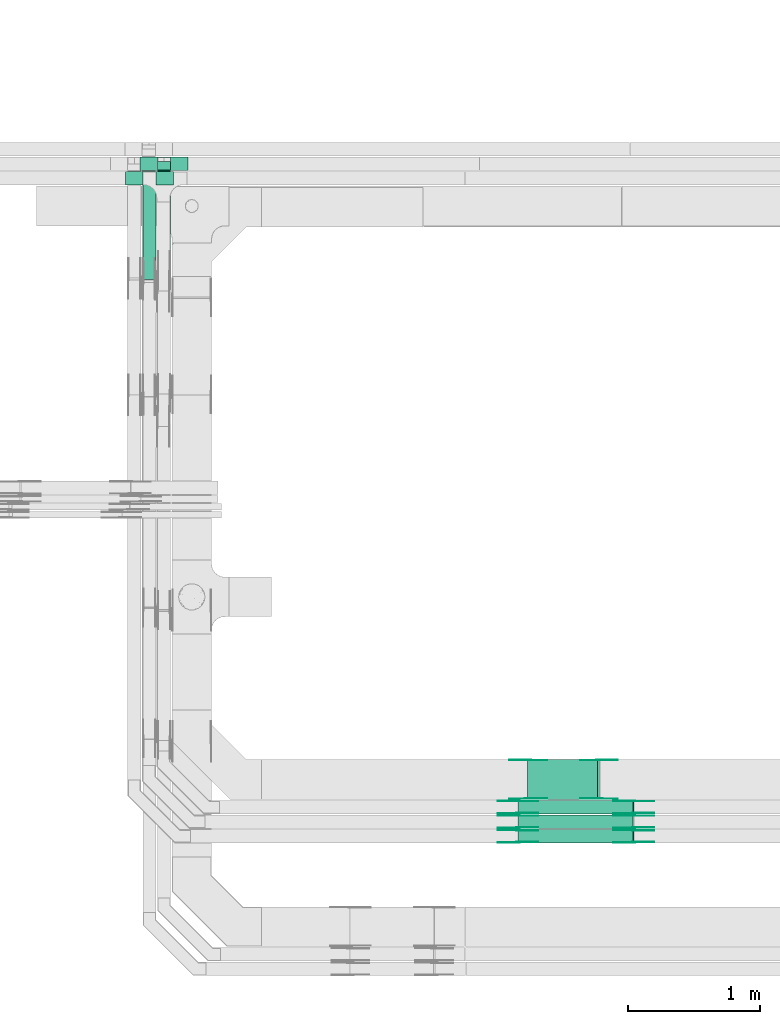
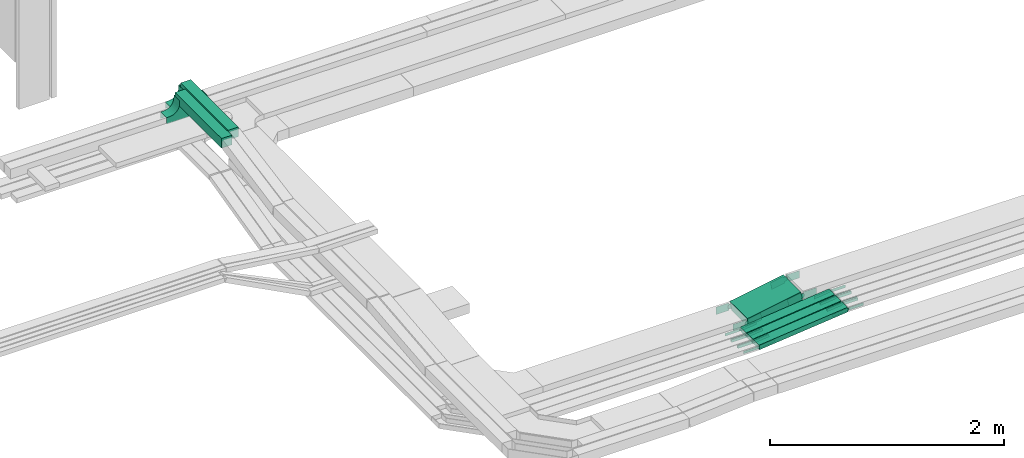
# One storey, part 10 of 33: 34 flow fittings, 6 flow segments.
"""IFC2X3 building model written with IfcOpenShell, lengths in millimetres."""

from ifc_helpers import new_model, entity, si_unit, converted_unit, derived_unit, direction, frame, frame_2d, origin, origin_2d_with_axis, place, context, subcontext, project, spatial, polyline, circle_curve, parameter, trimmed, segment, composite_curve, rectangle, outline, extrude, source, transform, mapped, material, material_list, type_object, type_shapes, element, save


model = new_model("IFC2X3")

# Units and contexts
model_context = context("Model", 3, precision=0.01, world=origin(), true_north=direction((6.12303176911189e-17, 1.0)))
body_context = subcontext(model_context, "Body", "Model", "MODEL_VIEW")
ifc_project = project(units=[si_unit("LENGTHUNIT", "METRE", prefix="MILLI"), si_unit("AREAUNIT", "SQUARE_METRE"), si_unit("VOLUMEUNIT", "CUBIC_METRE"), converted_unit("PLANEANGLEUNIT", "DEGREE", entity("IfcRatioMeasure", 0.0174532925199433), si_unit("PLANEANGLEUNIT", "RADIAN"), dimensions=[0, 0, 0, 0, 0, 0, 0]), si_unit("MASSUNIT", "GRAM", prefix="KILO"), derived_unit("MASSDENSITYUNIT", [(si_unit("MASSUNIT", "GRAM", prefix="KILO"), 1), (si_unit("LENGTHUNIT", "METRE"), -3)]), derived_unit("MOMENTOFINERTIAUNIT", [(si_unit("LENGTHUNIT", "METRE"), 4)]), si_unit("TIMEUNIT", "SECOND"), si_unit("FREQUENCYUNIT", "HERTZ"), si_unit("THERMODYNAMICTEMPERATUREUNIT", "DEGREE_CELSIUS"), derived_unit("THERMALTRANSMITTANCEUNIT", [(si_unit("MASSUNIT", "GRAM", prefix="KILO"), 1), (si_unit("THERMODYNAMICTEMPERATUREUNIT", "KELVIN"), -1), (si_unit("TIMEUNIT", "SECOND"), -3)]), derived_unit("VOLUMETRICFLOWRATEUNIT", [(si_unit("LENGTHUNIT", "METRE"), 3), (si_unit("TIMEUNIT", "SECOND"), -1)]), derived_unit("MASSFLOWRATEUNIT", [(si_unit("MASSUNIT", "GRAM", prefix="KILO"), 1), (si_unit("TIMEUNIT", "SECOND"), -1)]), derived_unit("ROTATIONALFREQUENCYUNIT", [(si_unit("TIMEUNIT", "SECOND"), -1)]), si_unit("ELECTRICCURRENTUNIT", "AMPERE"), si_unit("ELECTRICVOLTAGEUNIT", "VOLT"), si_unit("POWERUNIT", "WATT"), si_unit("FORCEUNIT", "NEWTON", prefix="KILO"), si_unit("ILLUMINANCEUNIT", "LUX"), si_unit("LUMINOUSFLUXUNIT", "LUMEN"), si_unit("LUMINOUSINTENSITYUNIT", "CANDELA"), derived_unit("USERDEFINED", [(si_unit("MASSUNIT", "GRAM", prefix="KILO"), -1), (si_unit("LENGTHUNIT", "METRE"), -2), (si_unit("TIMEUNIT", "SECOND"), 3), (si_unit("LUMINOUSFLUXUNIT", "LUMEN"), 1)]), derived_unit("LINEARVELOCITYUNIT", [(si_unit("LENGTHUNIT", "METRE"), 1), (si_unit("TIMEUNIT", "SECOND"), -1)]), si_unit("PRESSUREUNIT", "PASCAL"), derived_unit("USERDEFINED", [(si_unit("LENGTHUNIT", "METRE"), -2), (si_unit("MASSUNIT", "GRAM", prefix="KILO"), 1), (si_unit("TIMEUNIT", "SECOND"), -2)]), derived_unit("LINEARFORCEUNIT", [(si_unit("MASSUNIT", "GRAM", prefix="KILO"), 1), (si_unit("LENGTHUNIT", "METRE"), 1), (si_unit("TIMEUNIT", "SECOND"), -2), (si_unit("LENGTHUNIT", "METRE"), -1)]), derived_unit("PLANARFORCEUNIT", [(si_unit("MASSUNIT", "GRAM", prefix="KILO"), 1), (si_unit("LENGTHUNIT", "METRE"), 1), (si_unit("TIMEUNIT", "SECOND"), -2), (si_unit("LENGTHUNIT", "METRE"), -2)])], contexts=[model_context])

# Site, building, storey
site_placement = place(None, frame((0.0, -0.00077364408347762, 0.0)))
site = spatial("IfcSite", under=ifc_project, at=site_placement, CompositionType="ELEMENT")
building_placement = place(site_placement, origin())
building = spatial("IfcBuilding", under=site, at=building_placement, CompositionType="ELEMENT")
storey_placement = place(building_placement, frame((0.0, 0.0, 8100.0)))
storey = spatial("IfcBuildingStorey", under=building, at=storey_placement, CompositionType="ELEMENT", Elevation=8100.0)

# Flow segments
cable_carrier_segment_type = type_object("IfcCableCarrierSegmentType", PredefinedType="CABLETRAYSEGMENT")
flow_segment_1_placement = place(storey_placement, frame((20936.6119881971, 9844.99855346682, 2501.75364186438)))
element("IfcFlowSegment", 1, at=flow_segment_1_placement, inside=storey, type_object=cable_carrier_segment_type, context=body_context, shape_type="SweptSolid", body=[
    extrude(rectangle(XDim=99.9999999999988, YDim=300.000000000001, at=origin_2d_with_axis()), frame((8.68240888335646, 150.0, 49.2403876506095), z_axis=(0.98480775301218, 0.0, 0.173648177667088), x_axis=(-0.173648177667088, 0.0, 0.98480775301218)), (0.0, 0.0, 1.0), 535.73303583543),
])
flow_segment_2_placement = place(storey_placement, frame((20862.9583340614, 9515.4751966114, 2500.38811547991)))
element("IfcFlowSegment", 2, at=flow_segment_2_placement, inside=storey, type_object=cable_carrier_segment_type, context=body_context, shape_type="SweptSolid", body=[
    extrude(rectangle(XDim=49.9999999999994, YDim=100.000000000001, at=origin_2d_with_axis()), frame((2.56705800013261, 50.0, 24.8678550185564), z_axis=(0.994714200742268, 0.0, 0.102682320005306), x_axis=(-0.102682320005306, 0.0, 0.994714200742268)), (0.0, 0.0, 1.0), 876.300550533938),
])
flow_segment_3_placement = place(storey_placement, frame((20863.3945823031, 9625.47519661138, 2495.89018816181)))
element("IfcFlowSegment", 3, at=flow_segment_3_placement, inside=storey, type_object=cable_carrier_segment_type, context=body_context, shape_type="SweptSolid", body=[
    extrude(rectangle(XDim=50.0000000000006, YDim=100.000000000001, at=origin_2d_with_axis()), frame((2.69638057909248, 50.0, 24.854165280146), z_axis=(0.994166611205742, 0.0, 0.107855223163698), x_axis=(-0.107855223163698, 0.0, 0.994166611205742)), (0.0, 0.0, 1.0), 875.337574347223),
])
flow_segment_4_placement = place(storey_placement, frame((20863.4181872232, 9734.99855346672, 2495.73503380325)))
element("IfcFlowSegment", 4, at=flow_segment_4_placement, inside=storey, type_object=cable_carrier_segment_type, context=body_context, shape_type="SweptSolid", body=[
    extrude(rectangle(XDim=50.0000000000009, YDim=99.9999999999989, at=origin_2d_with_axis()), frame((2.66402572466178, 50.0, 24.8576540916146), z_axis=(0.994306163664565, 0.0, 0.106561028986469), x_axis=(-0.106561028986469, 0.0, 0.994306163664565)), (0.0, 0.0, 1.0), 875.4694098787),
])
flow_segment_5_placement = place(storey_placement, frame((18026.0523642072, 13775.3539584061, 3012.11789102291)))
element("IfcFlowSegment", 5, at=flow_segment_5_placement, inside=storey, type_object=cable_carrier_segment_type, context=body_context, shape_type="SweptSolid", body=[
    extrude(rectangle(XDim=793.729321151489, YDim=99.9999999999989, at=frame_2d((-1.08002495835535e-12, 0.0), x_axis=(1.0, 0.0))), frame((50.0, 396.864660575752, 0.0), z_axis=(0.0, 0.0, 1.0), x_axis=(0.0, -1.0, 0.0)), (0.0, 0.0, 1.0), 99.9999999999989),
])
flow_segment_6_placement = place(storey_placement, frame((18136.0523642072, 13853.7575403383, 3012.11789102291)))
element("IfcFlowSegment", 6, at=flow_segment_6_placement, inside=storey, type_object=cable_carrier_segment_type, context=body_context, shape_type="SweptSolid", body=[
    extrude(rectangle(XDim=814.055739224407, YDim=99.9999999999989, at=frame_2d((1.08002495835535e-12, 0.0), x_axis=(1.0, 0.0))), frame((50.0, 407.027869612207, 0.0), z_axis=(0.0, 0.0, 1.0), x_axis=(0.0, -1.0, 0.0)), (0.0, 0.0, 1.0), 99.9999999999989),
])

# Flow fittings
ifc_material_1 = material(Name="G")
cable_carrier_fitting_type_1 = type_object("IfcCableCarrierFittingType", PredefinedType="NOTDEFINED", material=ifc_material_1)
shared_shape_1 = source(origin(), body_context, "Body", "SweptSolid", [
    extrude(outline(composite_curve([segment(trimmed(circle_curve(frame_2d((-44.5901162790698, 0.0), x_axis=(1.0, 0.0)), 12.5), [parameter(90.0000000000007)], [parameter(270.0)], True, "PARAMETER"), True, "CONTINUOUS"), segment(polyline([(-44.5901162790697, -12.5), (-33.0901162790698, -12.5)]), True, "CONTINUOUS"), segment(polyline([(-33.0901162790698, -12.5), (-31.2296511627907, -14.5)]), True, "CONTINUOUS"), segment(polyline([(-31.2296511627907, -14.5), (108.90988372093, -14.5)]), True, "CONTINUOUS"), segment(polyline([(108.90988372093, -14.5), (108.90988372093, 14.5)]), True, "CONTINUOUS"), segment(polyline([(108.90988372093, 14.5), (-31.2296511627907, 14.5)]), True, "CONTINUOUS"), segment(polyline([(-31.2296511627907, 14.5), (-33.0901162790698, 12.5)]), True, "CONTINUOUS"), segment(polyline([(-33.0901162790698, 12.5), (-44.5901162790699, 12.5)]), True, "CONTINUOUS")], self_intersect=False)), frame((44.5901162790698, 0.0, 0.0), z_axis=(0.0, 0.0, -1.0), x_axis=(1.0, 0.0, 0.0)), (0.0, 0.0, -1.0), 2.0),
])
type_shapes(cable_carrier_fitting_type_1, [shared_shape_1])
for number, where, z_axis, x_axis in (
    (7, (21739.6736562129, 9520.01519660124, 2615.49251454772), (0.0, -1.0, 0.0), (-0.994714200742261, 0.0, -0.102682320005368)),
    (8, (21738.8758454154, 9630.01519660122, 2615.43110636497), (0.0, -1.0, 0.0), (-0.99416661120574, 0.0, -0.107855223163717)),
    (9, (21739.1018729423, 9739.53855345656, 2614.15529134039), (0.0, -1.0, 0.0), (-0.994306163664572, 0.0, -0.106561028986405)),
    (10, (20863.5374702987, 9720.93519662154, 2520.46732994372), (0.0, 1.0, 0.0), (-1.0, 0.0, 0.0)),
    (11, (20863.5471832954, 9830.45855347687, 2520.32100561212), (0.0, 1.0, 0.0), (-1.0, 0.0, 0.0)),
    (12, (20863.0457296445, 9610.93519662156, 2525.0), (0.0, 1.0, 0.0), (-1.0, 0.0, 0.0)),
):
    element("IfcFlowFitting", number, at=place(storey_placement, frame(where, z_axis=z_axis, x_axis=x_axis)), inside=storey, type_object=cable_carrier_fitting_type_1, material=ifc_material_1, context=body_context, shape_type="MappedRepresentation", body=[
        mapped(shared_shape_1, transform((0.0, 0.0, 0.0), scale=1.0)),
    ])
cable_carrier_fitting_type_2 = type_object("IfcCableCarrierFittingType", PredefinedType="NOTDEFINED", material=ifc_material_1)
shared_shape_2 = source(origin(), body_context, "Body", "SweptSolid", [
    extrude(outline(composite_curve([segment(trimmed(circle_curve(frame_2d((-44.5901162790697, 0.0), x_axis=(1.0, 0.0)), 12.5), [parameter(90.0000000000007)], [parameter(270.0)], True, "PARAMETER"), True, "CONTINUOUS"), segment(polyline([(-44.5901162790697, -12.5), (-33.0901162790697, -12.5)]), True, "CONTINUOUS"), segment(polyline([(-33.0901162790697, -12.5), (-31.2296511627907, -14.5)]), True, "CONTINUOUS"), segment(polyline([(-31.2296511627907, -14.5), (108.90988372093, -14.5)]), True, "CONTINUOUS"), segment(polyline([(108.90988372093, -14.5), (108.90988372093, 14.5)]), True, "CONTINUOUS"), segment(polyline([(108.90988372093, 14.5), (-31.2296511627907, 14.5)]), True, "CONTINUOUS"), segment(polyline([(-31.2296511627907, 14.5), (-33.0901162790698, 12.5)]), True, "CONTINUOUS"), segment(polyline([(-33.0901162790698, 12.5), (-44.5901162790699, 12.5)]), True, "CONTINUOUS")], self_intersect=False)), frame((44.5901162790697, 0.0, 0.0)), (0.0, 0.0, 1.0), 2.0),
])
type_shapes(cable_carrier_fitting_type_2, [shared_shape_2])
for number, where, z_axis, x_axis in (
    (13, (21739.6736562129, 9610.93519662156, 2615.49251454772), (0.0, 1.0, 0.0), (-0.994714200742261, 0.0, -0.102682320005368)),
    (14, (21738.8758454154, 9720.93519662154, 2615.43110636498), (0.0, 1.0, 0.0), (-0.99416661120574, 0.0, -0.107855223163717)),
    (15, (21739.1018729423, 9830.45855347688, 2614.15529134039), (0.0, 1.0, 0.0), (-0.994306163664572, 0.0, -0.106561028986405)),
    (16, (20863.5374702987, 9630.01519660122, 2520.46732994372), (0.0, -1.0, 0.0), (-1.0, 0.0, 0.0)),
    (17, (20863.5471832954, 9739.53855345656, 2520.32100561212), (0.0, -1.0, 0.0), (-1.0, 0.0, 0.0)),
    (18, (20863.0457296445, 9520.01519660125, 2525.0), (0.0, -1.0, 0.0), (-1.0, 0.0, 0.0)),
):
    element("IfcFlowFitting", number, at=place(storey_placement, frame(where, z_axis=z_axis, x_axis=x_axis)), inside=storey, type_object=cable_carrier_fitting_type_2, material=ifc_material_1, context=body_context, shape_type="MappedRepresentation", body=[
        mapped(shared_shape_2, transform((0.0, 0.0, 0.0), scale=1.0)),
    ])
cable_carrier_fitting_type_3 = type_object("IfcCableCarrierFittingType", PredefinedType="NOTDEFINED", material=ifc_material_1)
shared_shape_3 = source(origin(), body_context, "Body", "SweptSolid", [
    extrude(outline(composite_curve([segment(trimmed(circle_curve(frame_2d((-44.5901162790698, 0.0), x_axis=(1.0, 0.0)), 12.5), [parameter(90.0000000000007)], [parameter(270.0)], True, "PARAMETER"), True, "CONTINUOUS"), segment(polyline([(-44.5901162790697, -12.5), (-33.0901162790698, -12.5)]), True, "CONTINUOUS"), segment(polyline([(-33.0901162790698, -12.5), (-31.2296511627907, -14.5)]), True, "CONTINUOUS"), segment(polyline([(-31.2296511627907, -14.5), (108.90988372093, -14.5)]), True, "CONTINUOUS"), segment(polyline([(108.90988372093, -14.5), (108.90988372093, 14.5)]), True, "CONTINUOUS"), segment(polyline([(108.90988372093, 14.5), (-31.2296511627907, 14.5)]), True, "CONTINUOUS"), segment(polyline([(-31.2296511627907, 14.5), (-33.0901162790698, 12.5)]), True, "CONTINUOUS"), segment(polyline([(-33.0901162790698, 12.5), (-44.5901162790699, 12.5)]), True, "CONTINUOUS")], self_intersect=False)), frame((44.5901162790698, 0.0, 0.0), z_axis=(0.0, 0.0, -1.0), x_axis=(1.0, 0.0, 0.0)), (0.0, 0.0, -1.0), 2.0),
])
type_shapes(cable_carrier_fitting_type_3, [shared_shape_3])
for number, where, z_axis, x_axis in (
    (19, (21739.6736562129, 9608.93519662156, 2615.49251454772), (0.0, 1.0, 0.0), (1.0, 0.0, 0.0)),
    (20, (21738.8758454154, 9718.93519662154, 2615.43110636497), (0.0, 1.0, 0.0), (1.0, 0.0, 0.0)),
    (21, (21739.1018729423, 9828.45855347688, 2614.15529134039), (0.0, 1.0, 0.0), (1.0, 0.0, 0.0)),
    (22, (20863.5374702987, 9632.01519660122, 2520.46732994373), (0.0, -1.0, 0.0), (0.994166611205741, 0.0, 0.107855223163708)),
    (23, (20863.5471832954, 9741.53855345656, 2520.32100561212), (0.0, -1.0, 0.0), (0.994306163664573, 0.0, 0.106561028986395)),
    (24, (20863.0457296444, 9522.01519660125, 2525.0), (0.0, -1.0, 0.0), (0.994714200742268, 0.0, 0.102682320005305)),
):
    element("IfcFlowFitting", number, at=place(storey_placement, frame(where, z_axis=z_axis, x_axis=x_axis)), inside=storey, type_object=cable_carrier_fitting_type_3, material=ifc_material_1, context=body_context, shape_type="MappedRepresentation", body=[
        mapped(shared_shape_3, transform((0.0, 0.0, 0.0), scale=1.0)),
    ])
cable_carrier_fitting_type_4 = type_object("IfcCableCarrierFittingType", PredefinedType="NOTDEFINED", material=ifc_material_1)
shared_shape_4 = source(origin(), body_context, "Body", "SweptSolid", [
    extrude(outline(composite_curve([segment(trimmed(circle_curve(frame_2d((-44.5901162790697, 0.0), x_axis=(1.0, 0.0)), 12.5), [parameter(90.0000000000007)], [parameter(270.0)], True, "PARAMETER"), True, "CONTINUOUS"), segment(polyline([(-44.5901162790697, -12.5), (-33.0901162790697, -12.5)]), True, "CONTINUOUS"), segment(polyline([(-33.0901162790697, -12.5), (-31.2296511627907, -14.5)]), True, "CONTINUOUS"), segment(polyline([(-31.2296511627907, -14.5), (108.90988372093, -14.5)]), True, "CONTINUOUS"), segment(polyline([(108.90988372093, -14.5), (108.90988372093, 14.5)]), True, "CONTINUOUS"), segment(polyline([(108.90988372093, 14.5), (-31.2296511627907, 14.5)]), True, "CONTINUOUS"), segment(polyline([(-31.2296511627907, 14.5), (-33.0901162790698, 12.5)]), True, "CONTINUOUS"), segment(polyline([(-33.0901162790698, 12.5), (-44.5901162790699, 12.5)]), True, "CONTINUOUS")], self_intersect=False)), frame((44.5901162790697, 0.0, 0.0)), (0.0, 0.0, 1.0), 2.0),
])
type_shapes(cable_carrier_fitting_type_4, [shared_shape_4])
for number, where, z_axis, x_axis in (
    (25, (21739.6736562129, 9522.01519660124, 2615.49251454771), (0.0, -1.0, 0.0), (1.0, 0.0, 0.0)),
    (26, (21738.8758454154, 9632.01519660122, 2615.43110636497), (0.0, -1.0, 0.0), (1.0, 0.0, 0.0)),
    (27, (21739.1018729423, 9741.53855345656, 2614.15529134039), (0.0, -1.0, 0.0), (1.0, 0.0, 0.0)),
    (28, (20863.5374702987, 9718.93519662153, 2520.46732994373), (0.0, 1.0, 0.0), (0.994166611205741, 0.0, 0.107855223163708)),
    (29, (20863.5471832954, 9828.45855347687, 2520.32100561212), (0.0, 1.0, 0.0), (0.994306163664573, 0.0, 0.106561028986395)),
    (30, (20863.0457296444, 9608.93519662156, 2525.0), (0.0, 1.0, 0.0), (0.994714200742268, 0.0, 0.102682320005305)),
):
    element("IfcFlowFitting", number, at=place(storey_placement, frame(where, z_axis=z_axis, x_axis=x_axis)), inside=storey, type_object=cable_carrier_fitting_type_4, material=ifc_material_1, context=body_context, shape_type="MappedRepresentation", body=[
        mapped(shared_shape_4, transform((0.0, 0.0, 0.0), scale=1.0)),
    ])
cable_carrier_fitting_type_5 = type_object("IfcCableCarrierFittingType", PredefinedType="NOTDEFINED", material=ifc_material_1)
shared_shape_5 = source(origin(), body_context, "Body", "SweptSolid", [
    extrude(outline(composite_curve([segment(trimmed(circle_curve(frame_2d((-41.4651162790697, 0.0), x_axis=(1.0, 0.0)), 25.0), [parameter(90.0000000000007)], [parameter(270.0)], True, "PARAMETER"), True, "CONTINUOUS"), segment(polyline([(-41.4651162790697, -25.0), (-29.9651162790697, -25.0)]), True, "CONTINUOUS"), segment(polyline([(-29.9651162790697, -25.0), (-28.1046511627907, -38.5)]), True, "CONTINUOUS"), segment(polyline([(-28.1046511627907, -38.5), (99.5348837209303, -38.5)]), True, "CONTINUOUS"), segment(polyline([(99.5348837209303, -38.5), (99.5348837209303, 38.5)]), True, "CONTINUOUS"), segment(polyline([(99.5348837209303, 38.5), (-28.1046511627907, 38.5)]), True, "CONTINUOUS"), segment(polyline([(-28.1046511627907, 38.5), (-29.9651162790697, 25.0)]), True, "CONTINUOUS"), segment(polyline([(-29.9651162790697, 25.0), (-41.46511627907, 25.0)]), True, "CONTINUOUS")], self_intersect=False)), frame((41.4651162790697, 0.0, 0.0), z_axis=(0.0, 0.0, -1.0), x_axis=(1.0, 0.0, 0.0)), (0.0, 0.0, -1.0), 2.0),
])
type_shapes(cable_carrier_fitting_type_5, [shared_shape_5])
for number, where, z_axis, x_axis in (
    (31, (21478.5258658324, 10140.458553477, 2645.01712441888), (0.0, 1.0, 0.0), (1.0, 0.0, 0.0)),
    (32, (20939.656975564, 10140.458553477, 2550.0), (0.0, 1.0, 0.0), (-1.0, 0.0, 0.0)),
):
    element("IfcFlowFitting", number, at=place(storey_placement, frame(where, z_axis=z_axis, x_axis=x_axis)), inside=storey, type_object=cable_carrier_fitting_type_5, material=ifc_material_1, context=body_context, shape_type="MappedRepresentation", body=[
        mapped(shared_shape_5, transform((0.0, 0.0, 0.0), scale=1.0)),
    ])
cable_carrier_fitting_type_6 = type_object("IfcCableCarrierFittingType", PredefinedType="NOTDEFINED", material=ifc_material_1)
shared_shape_6 = source(origin(), body_context, "Body", "SweptSolid", [
    extrude(outline(composite_curve([segment(trimmed(circle_curve(frame_2d((-41.4651162790697, 0.0), x_axis=(1.0, 0.0)), 25.0), [parameter(90.0000000000007)], [parameter(270.0)], True, "PARAMETER"), True, "CONTINUOUS"), segment(polyline([(-41.4651162790697, -25.0), (-29.9651162790697, -25.0)]), True, "CONTINUOUS"), segment(polyline([(-29.9651162790697, -25.0), (-28.1046511627907, -38.5)]), True, "CONTINUOUS"), segment(polyline([(-28.1046511627907, -38.5), (99.5348837209303, -38.5)]), True, "CONTINUOUS"), segment(polyline([(99.5348837209303, -38.5), (99.5348837209303, 38.5)]), True, "CONTINUOUS"), segment(polyline([(99.5348837209303, 38.5), (-28.1046511627907, 38.5)]), True, "CONTINUOUS"), segment(polyline([(-28.1046511627907, 38.5), (-29.9651162790697, 25.0)]), True, "CONTINUOUS"), segment(polyline([(-29.9651162790697, 25.0), (-41.46511627907, 25.0)]), True, "CONTINUOUS")], self_intersect=False)), frame((41.4651162790697, 0.0, 0.0)), (0.0, 0.0, 1.0), 2.0),
])
type_shapes(cable_carrier_fitting_type_6, [shared_shape_6])
for number, where, z_axis, x_axis in (
    (33, (21478.5258658324, 9849.53855345666, 2645.01712441888), (0.0, -1.0, 0.0), (1.0, 0.0, 0.0)),
    (34, (20939.656975564, 9849.53855345666, 2550.0), (0.0, -1.0, 0.0), (-1.0, 0.0, 0.0)),
):
    element("IfcFlowFitting", number, at=place(storey_placement, frame(where, z_axis=z_axis, x_axis=x_axis)), inside=storey, type_object=cable_carrier_fitting_type_6, material=ifc_material_1, context=body_context, shape_type="MappedRepresentation", body=[
        mapped(shared_shape_6, transform((0.0, 0.0, 0.0), scale=1.0)),
    ])
cable_carrier_fitting_type_7 = type_object("IfcCableCarrierFittingType", PredefinedType="NOTDEFINED", material=ifc_material_1)
shared_shape_7 = source(origin(), body_context, "Body", "SweptSolid", [
    extrude(outline(composite_curve([segment(trimmed(circle_curve(frame_2d((-41.4651162790697, 0.0), x_axis=(1.0, 0.0)), 25.0), [parameter(90.0000000000007)], [parameter(270.0)], True, "PARAMETER"), True, "CONTINUOUS"), segment(polyline([(-41.4651162790697, -25.0), (-29.9651162790697, -25.0)]), True, "CONTINUOUS"), segment(polyline([(-29.9651162790697, -25.0), (-28.1046511627907, -38.5)]), True, "CONTINUOUS"), segment(polyline([(-28.1046511627907, -38.5), (99.5348837209303, -38.5)]), True, "CONTINUOUS"), segment(polyline([(99.5348837209303, -38.5), (99.5348837209303, 38.5)]), True, "CONTINUOUS"), segment(polyline([(99.5348837209303, 38.5), (-28.1046511627907, 38.5)]), True, "CONTINUOUS"), segment(polyline([(-28.1046511627907, 38.5), (-29.9651162790697, 25.0)]), True, "CONTINUOUS"), segment(polyline([(-29.9651162790697, 25.0), (-41.46511627907, 25.0)]), True, "CONTINUOUS")], self_intersect=False)), frame((41.4651162790697, 0.0, 0.0), z_axis=(0.0, 0.0, -1.0), x_axis=(1.0, 0.0, 0.0)), (0.0, 0.0, -1.0), 2.0),
])
type_shapes(cable_carrier_fitting_type_7, [shared_shape_7])
for number, where, z_axis, x_axis in (
    (35, (21478.5258658324, 9851.53855345666, 2645.01712441887), (0.0, -1.0, 0.0), (-0.98480775301218, 0.0, -0.173648177667088)),
    (36, (20939.6569755639, 9851.53855345667, 2550.0), (0.0, -1.0, 0.0), (0.984807753012183, 0.0, 0.173648177667075)),
):
    element("IfcFlowFitting", number, at=place(storey_placement, frame(where, z_axis=z_axis, x_axis=x_axis)), inside=storey, type_object=cable_carrier_fitting_type_7, material=ifc_material_1, context=body_context, shape_type="MappedRepresentation", body=[
        mapped(shared_shape_7, transform((0.0, 0.0, 0.0), scale=1.0)),
    ])
cable_carrier_fitting_type_8 = type_object("IfcCableCarrierFittingType", PredefinedType="NOTDEFINED", material=ifc_material_1)
shared_shape_8 = source(origin(), body_context, "Body", "SweptSolid", [
    extrude(outline(composite_curve([segment(trimmed(circle_curve(frame_2d((-41.4651162790697, 0.0), x_axis=(1.0, 0.0)), 25.0), [parameter(90.0000000000007)], [parameter(270.0)], True, "PARAMETER"), True, "CONTINUOUS"), segment(polyline([(-41.4651162790697, -25.0), (-29.9651162790697, -25.0)]), True, "CONTINUOUS"), segment(polyline([(-29.9651162790697, -25.0), (-28.1046511627907, -38.5)]), True, "CONTINUOUS"), segment(polyline([(-28.1046511627907, -38.5), (99.5348837209303, -38.5)]), True, "CONTINUOUS"), segment(polyline([(99.5348837209303, -38.5), (99.5348837209303, 38.5)]), True, "CONTINUOUS"), segment(polyline([(99.5348837209303, 38.5), (-28.1046511627907, 38.5)]), True, "CONTINUOUS"), segment(polyline([(-28.1046511627907, 38.5), (-29.9651162790697, 25.0)]), True, "CONTINUOUS"), segment(polyline([(-29.9651162790697, 25.0), (-41.46511627907, 25.0)]), True, "CONTINUOUS")], self_intersect=False)), frame((41.4651162790697, 0.0, 0.0)), (0.0, 0.0, 1.0), 2.0),
])
type_shapes(cable_carrier_fitting_type_8, [shared_shape_8])
for number, where, z_axis, x_axis in (
    (37, (21478.5258658324, 10138.458553477, 2645.01712441887), (0.0, 1.0, 0.0), (-0.98480775301218, 0.0, -0.173648177667088)),
    (38, (20939.6569755639, 10138.458553477, 2550.0), (0.0, 1.0, 0.0), (0.984807753012183, 0.0, 0.173648177667075)),
):
    element("IfcFlowFitting", number, at=place(storey_placement, frame(where, z_axis=z_axis, x_axis=x_axis)), inside=storey, type_object=cable_carrier_fitting_type_8, material=ifc_material_1, context=body_context, shape_type="MappedRepresentation", body=[
        mapped(shared_shape_8, transform((0.0, 0.0, 0.0), scale=1.0)),
    ])
ifc_material_2 = material()
ifc_material_list_1 = material_list([ifc_material_2, ifc_material_2, ifc_material_2, ifc_material_2])
ifc_material_list_2 = material_list([ifc_material_2, ifc_material_2, ifc_material_2, ifc_material_2])
cable_carrier_fitting_type_9 = type_object("IfcCableCarrierFittingType", Name="470_DKC_S5_TSS cover (flat)", PredefinedType="NOTDEFINED", material=ifc_material_list_2)
shared_shape_9 = source(origin(), body_context, "Body", "SweptSolid", [
    extrude(outline(composite_curve([segment(polyline([(-72.7500000000004, -57.2500000000001), (-72.7500000000004, -58.2500000000001)]), True, "CONTINUOUS"), segment(polyline([(-72.7500000000004, -58.2500000000001), (-42.7499999999991, -58.2500000000001)]), True, "CONTINUOUS"), segment(trimmed(circle_curve(frame_2d((-42.7499999999995, 42.7500000000001), x_axis=(0.0, 1.0)), 101.0), [parameter(180.0)], [parameter(270.0)], True, "PARAMETER"), True, "CONTINUOUS"), segment(polyline([(58.2500000000007, 42.7499999999998), (58.2500000000007, 72.7500000000001)]), True, "CONTINUOUS"), segment(polyline([(58.2500000000007, 72.7500000000001), (57.2499999999993, 72.7500000000001)]), True, "CONTINUOUS"), segment(polyline([(57.2499999999993, 72.7500000000001), (57.2499999999993, 42.7500000000002)]), True, "CONTINUOUS"), segment(trimmed(circle_curve(frame_2d((-42.7500000000007, 42.7499999999999), x_axis=(0.0, 1.0)), 100.0), [parameter(180.0)], [parameter(270.0)], True, "PARAMETER"), False, "CONTINUOUS"), segment(polyline([(-42.7499999999995, -57.2500000000001), (-72.7500000000004, -57.2500000000001)]), True, "CONTINUOUS")], self_intersect=False)), frame((107.25, -50.0, 107.250000000002), z_axis=(0.0, -1.0, 0.0), x_axis=(0.0, 0.0, -1.0)), (0.0, 0.0, -1.0), 100.0),
    extrude(outline(composite_curve([segment(polyline([(57.2499999999999, -72.7500000000004), (58.2500000000002, -72.7500000000004)]), True, "CONTINUOUS"), segment(polyline([(58.2500000000002, -72.7500000000004), (58.2500000000002, -42.7499999999995)]), True, "CONTINUOUS"), segment(trimmed(circle_curve(frame_2d((-42.75, -42.7499999999995), x_axis=(1.0, 0.0)), 101.0), [parameter(4.57999874130747e-13)], [parameter(90.0000000000007)], True, "PARAMETER"), True, "CONTINUOUS"), segment(polyline([(-42.7500000000003, 58.2500000000007), (-72.7500000000001, 58.2500000000007)]), True, "CONTINUOUS"), segment(polyline([(-72.7500000000001, 58.2500000000007), (-72.7500000000001, 57.2499999999993)]), True, "CONTINUOUS"), segment(polyline([(-72.7500000000001, 57.2499999999993), (-42.7499999999999, 57.2499999999993)]), True, "CONTINUOUS"), segment(trimmed(circle_curve(frame_2d((-42.7500000000001, -42.7500000000007), x_axis=(1.0, 0.0)), 100.0), [parameter(360.0)], [parameter(89.9999999999999)], True, "PARAMETER"), False, "CONTINUOUS"), segment(polyline([(57.2499999999999, -42.7500000000005), (57.2499999999999, -72.7500000000004)]), True, "CONTINUOUS")], self_intersect=False)), frame((-107.249999999999, -50.0, 107.250000000002), z_axis=(0.0, 1.0, 0.0), x_axis=(1.0, 0.0, 0.0)), (0.0, 0.0, 1.0), 100.0),
    extrude(outline(composite_curve([segment(polyline([(-50.0, -97.5999999999999), (50.0, -97.5999999999999)]), True, "CONTINUOUS"), segment(polyline([(50.0, -97.5999999999999), (50.0, -67.5999999999997)]), True, "CONTINUOUS"), segment(trimmed(circle_curve(frame_2d((150.0, -67.6000000000002), x_axis=(1.0, 0.0)), 100.0), [parameter(90.0000000000003)], [parameter(180.0)], True, "PARAMETER"), False, "CONTINUOUS"), segment(polyline([(150.0, 32.3999999999999), (180.0, 32.3999999999999)]), True, "CONTINUOUS"), segment(polyline([(180.0, 32.3999999999999), (180.0, 100.400000000001)]), True, "CONTINUOUS"), segment(polyline([(180.0, 100.400000000001), (-180.0, 100.400000000001)]), True, "CONTINUOUS"), segment(polyline([(-180.0, 100.400000000001), (-180.0, 32.3999999999999)]), True, "CONTINUOUS"), segment(polyline([(-180.0, 32.3999999999999), (-150.0, 32.3999999999999)]), True, "CONTINUOUS"), segment(trimmed(circle_curve(frame_2d((-150.0, -67.6000000000002), x_axis=(1.0, 0.0)), 100.0), [parameter(1.01777749806833e-13)], [parameter(90.0000000000002)], True, "PARAMETER"), False, "CONTINUOUS"), segment(polyline([(-50.0, -67.6000000000002), (-50.0, -97.5999999999999)]), True, "CONTINUOUS")], self_intersect=False)), frame((0.0, -50.0, 82.4000000000028), z_axis=(0.0, 1.0, 0.0), x_axis=(1.0, 0.0, 0.0)), (0.0, 0.0, 1.0), 1.0),
    extrude(outline(composite_curve([segment(polyline([(-150.0, -32.3999999999998), (-180.0, -32.3999999999998)]), True, "CONTINUOUS"), segment(polyline([(-180.0, -32.3999999999998), (-180.0, -100.400000000001)]), True, "CONTINUOUS"), segment(polyline([(-180.0, -100.400000000001), (180.0, -100.400000000001)]), True, "CONTINUOUS"), segment(polyline([(180.0, -100.400000000001), (180.0, -32.3999999999998)]), True, "CONTINUOUS"), segment(polyline([(180.0, -32.3999999999998), (150.0, -32.3999999999998)]), True, "CONTINUOUS"), segment(trimmed(circle_curve(frame_2d((150.0, 67.6000000000002), x_axis=(1.0, 0.0)), 100.0), [parameter(180.0)], [parameter(270.0)], True, "PARAMETER"), False, "CONTINUOUS"), segment(polyline([(50.0, 67.5999999999998), (50.0, 97.6)]), True, "CONTINUOUS"), segment(polyline([(50.0, 97.6), (-50.0, 97.6)]), True, "CONTINUOUS"), segment(polyline([(-50.0, 97.6), (-50.0, 67.6000000000002)]), True, "CONTINUOUS"), segment(trimmed(circle_curve(frame_2d((-150.0, 67.6000000000002), x_axis=(1.0, 0.0)), 100.0), [parameter(270.0)], [parameter(360.0)], True, "PARAMETER"), False, "CONTINUOUS")], self_intersect=False)), frame((0.0, 49.0, 82.4000000000027), z_axis=(0.0, -1.0, 0.0), x_axis=(1.0, 0.0, 0.0)), (0.0, 0.0, -1.0), 1.00000000000005),
])
type_shapes(cable_carrier_fitting_type_9, [shared_shape_9])
flow_fitting_1_placement = place(storey_placement, frame((18076.0523642072, 14542.2782357464, 2890.0), z_axis=(0.0, 0.0, 1.0), x_axis=(-1.0, 0.0, 0.0)))
element("IfcFlowFitting", 39, at=flow_fitting_1_placement, inside=storey, type_object=cable_carrier_fitting_type_9, material=ifc_material_list_1, Name="470_DKC_S5_cover (flat)", ObjectType="470_DKC_S5_TSS cover (flat)", context=body_context, shape_type="MappedRepresentation", body=[
    mapped(shared_shape_9, transform((0.0, 0.0, 0.0), scale=1.0)),
])
flow_fitting_2_placement = place(storey_placement, frame((18186.0523642072, 14652.2782357463, 2890.0), z_axis=(0.0, 0.0, 1.0), x_axis=(-1.0, 0.0, 0.0)))
element("IfcFlowFitting", 40, at=flow_fitting_2_placement, inside=storey, type_object=cable_carrier_fitting_type_9, material=ifc_material_2, Name="470_DKC_S5_cover (flat)", ObjectType="470_DKC_S5_TSS cover (flat)", context=body_context, shape_type="MappedRepresentation", body=[
    mapped(shared_shape_9, transform((0.0, 0.0, 0.0), scale=1.0)),
])

save(model, "model.ifc")
